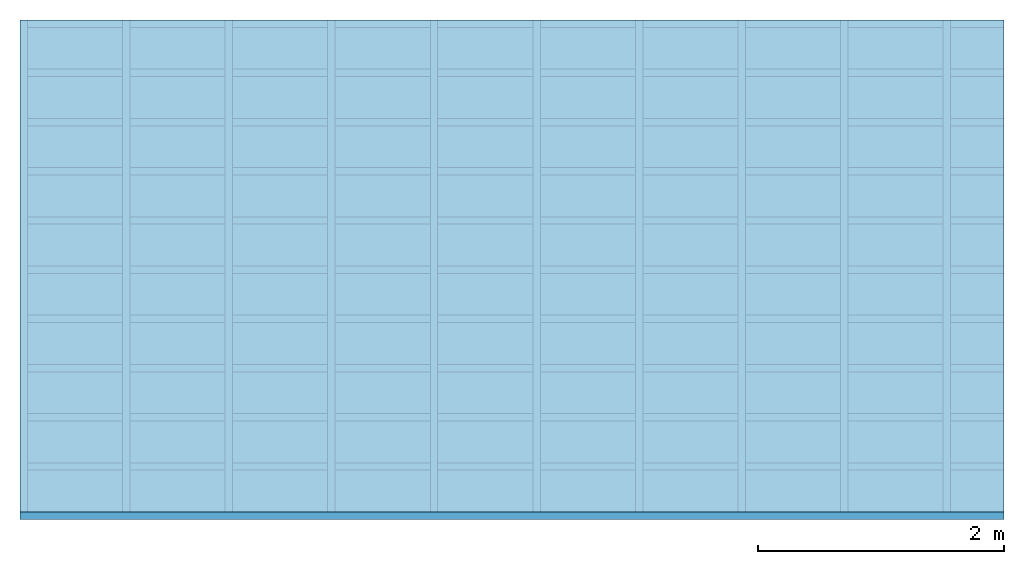
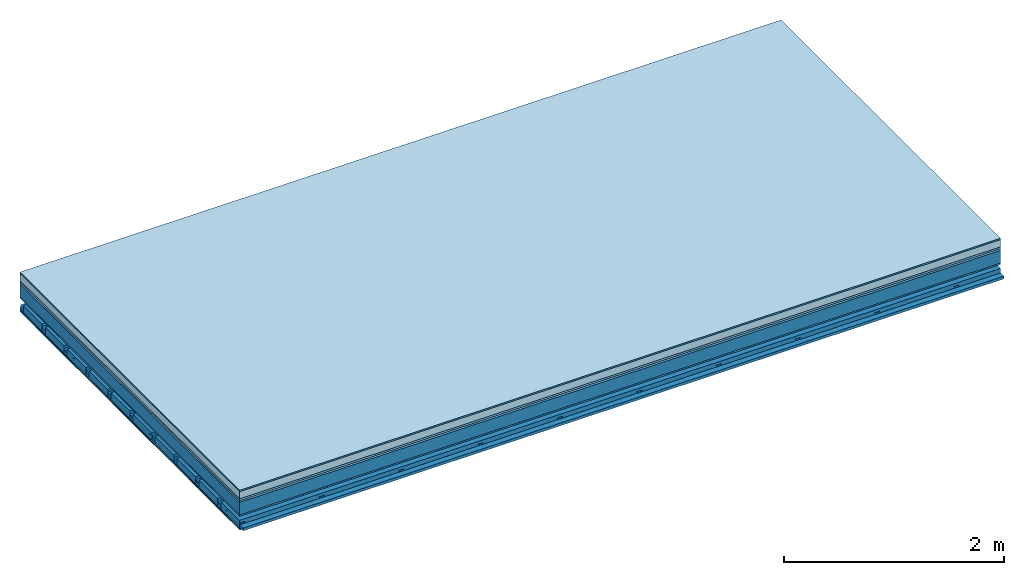
# One storey: 8 plates, 4 members, 1 element without a shape of its own.
"""IFC4 building model written with IfcOpenShell, lengths in metres."""

from ifc_helpers import new_model, si_unit, derived_unit, direction, frame, frame_2d, origin, origin_with_axes, place, context, project, spatial, polyline, rectangle, outline, extrude, material, layer, layer_set, type_object, element, aggregate, save


model = new_model("IFC4")

# Units and contexts
plan_context = context("Plan", 3, precision=1e-05, world=origin(), true_north=direction((0.0, 1.0)))
model_context = context("Model", 3, precision=1e-05, world=origin(), true_north=direction((0.0, 1.0)))
ifc_project = project(units=[si_unit("LENGTHUNIT", "METRE"), derived_unit("SOUNDPRESSUREUNIT", [(si_unit("PRESSUREUNIT", "PASCAL", prefix="MICRO"), 0)]), si_unit("ENERGYUNIT", "JOULE", prefix="MEGA"), si_unit("MASSUNIT", "GRAM", prefix="KILO"), derived_unit("THERMALTRANSMITTANCEUNIT", [(si_unit("POWERUNIT", "WATT"), 1), (si_unit("AREAUNIT", "SQUARE_METRE"), -1), (si_unit("THERMODYNAMICTEMPERATUREUNIT", "KELVIN"), -1)]), derived_unit("AREADENSITYUNIT", [(si_unit("MASSUNIT", "GRAM", prefix="KILO"), 1), (si_unit("AREAUNIT", "SQUARE_METRE"), -1)]), derived_unit("USERDEFINED", [(si_unit("ENERGYUNIT", "JOULE", prefix="MEGA"), 1), (si_unit("AREAUNIT", "SQUARE_METRE"), -1)])], contexts=[plan_context, model_context])

# Site, building, storey
site = spatial("IfcSite", under=ifc_project)
building_placement = place(None, origin())
building = spatial("IfcBuilding", under=site, at=building_placement)
storey_placement = place(building_placement, origin())
storey = spatial("IfcBuildingStorey", under=building, at=storey_placement)

# Slab, members, plates
ifc_material_1 = material(Category="11.013")
ifc_layer_1 = layer(ifc_material_1, 0.015, Name="Flooring")
ifc_material_2 = material(Name="Cement screed", Category="04.006")
ifc_layer_2 = layer(ifc_material_2, 0.08, Name="On-material")
ifc_material_3 = material(Name="Wood fiber generic product", Category="10.009")
ifc_layer_3 = layer(ifc_material_3, 0.02, Name="Impact sound insulation")
ifc_material_4 = material(Category="10.004")
ifc_layer_4 = layer(ifc_material_4, 0.02, Name="Additional insulation")
ifc_material_5 = material(Name="no composite action")
ifc_layer_5 = layer(ifc_material_5, 0.0, Name="Bond")
ifc_layer_6 = layer(None, 0.14, Name="Supporting structure")
ifc_material_6 = material(Name="of the art")
ifc_layer_7 = layer(ifc_material_6, 0.0, Name="Bond")
ifc_material_7 = material(Category="03.007")
ifc_layer_8 = layer(ifc_material_7, 0.015, Name="Lower layer 1")
ifc_layer_9 = layer(None, 0.095, Name="Coupling")
ifc_layer_10 = layer(None, 0.03, Name="Battens / profiles")
ifc_material_8 = material(Name="Plasterboard type A", Category="03.008")
ifc_layer_11 = layer(ifc_material_8, 0.0125, Name="Ceiling covering 1st layer")
ifc_layer_12 = layer(ifc_material_8, 0.0125, Name="Ceiling covering layer 2")
ifc_material_9 = material(Category="04.001")
ifc_layer_13 = layer(ifc_material_9, 0.003, Name="Surface / treatment")
ifc_layer_set = layer_set([ifc_layer_1, ifc_layer_2, ifc_layer_3, ifc_layer_4, ifc_layer_5, ifc_layer_6, ifc_layer_7, ifc_layer_8, ifc_layer_9, ifc_layer_10, ifc_layer_11, ifc_layer_12, ifc_layer_13])
slab_type = type_object("IfcSlabType", Name="A2160", PredefinedType="NOTDEFINED", material=ifc_layer_set)
slab_placement = place(None, frame((0.0, 0.0, 0.0), z_axis=(0.0, 0.0, -1.0), x_axis=(1.0, 0.0, 0.0)))
slab = element("IfcSlab", 1, at=slab_placement, inside=storey, type_object=slab_type, material=ifc_layer_set, Name="Slab #1")
ifc_material_10 = material(Name="Solid timber panel")
member_1_placement = place(slab_placement, origin())
member_1 = element("IfcMember", 2, at=member_1_placement, material=ifc_material_10, Name="Supporting structure", context=plan_context, shape_type="SweptSolid", body=[
    extrude(rectangle(XDim=1.0, YDim=0.14, at=frame_2d((0.5, 0.07), x_axis=(1.0, 0.0))), frame((0.0, 4.0, 0.135), z_axis=(0.0, -1.0, 0.0), x_axis=(1.0, 0.0, 0.0)), (0.0, 0.0, 1.0), 4.0),
    extrude(rectangle(XDim=1.0, YDim=0.14, at=frame_2d((0.5, 0.07), x_axis=(1.0, 0.0))), frame((1.0, 4.0, 0.135), z_axis=(0.0, -1.0, 0.0), x_axis=(1.0, 0.0, 0.0)), (0.0, 0.0, 1.0), 4.0),
    extrude(rectangle(XDim=1.0, YDim=0.14, at=frame_2d((0.5, 0.07), x_axis=(1.0, 0.0))), frame((2.0, 4.0, 0.135), z_axis=(0.0, -1.0, 0.0), x_axis=(1.0, 0.0, 0.0)), (0.0, 0.0, 1.0), 4.0),
    extrude(rectangle(XDim=1.0, YDim=0.14, at=frame_2d((0.5, 0.07), x_axis=(1.0, 0.0))), frame((3.0, 4.0, 0.135), z_axis=(0.0, -1.0, 0.0), x_axis=(1.0, 0.0, 0.0)), (0.0, 0.0, 1.0), 4.0),
    extrude(rectangle(XDim=1.0, YDim=0.14, at=frame_2d((0.5, 0.07), x_axis=(1.0, 0.0))), frame((4.0, 4.0, 0.135), z_axis=(0.0, -1.0, 0.0), x_axis=(1.0, 0.0, 0.0)), (0.0, 0.0, 1.0), 4.0),
    extrude(rectangle(XDim=1.0, YDim=0.14, at=frame_2d((0.5, 0.07), x_axis=(1.0, 0.0))), frame((5.0, 4.0, 0.135), z_axis=(0.0, -1.0, 0.0), x_axis=(1.0, 0.0, 0.0)), (0.0, 0.0, 1.0), 4.0),
    extrude(rectangle(XDim=1.0, YDim=0.14, at=frame_2d((0.5, 0.07), x_axis=(1.0, 0.0))), frame((6.0, 4.0, 0.135), z_axis=(0.0, -1.0, 0.0), x_axis=(1.0, 0.0, 0.0)), (0.0, 0.0, 1.0), 4.0),
    extrude(rectangle(XDim=1.0, YDim=0.14, at=frame_2d((0.5, 0.07), x_axis=(1.0, 0.0))), frame((7.0, 4.0, 0.135), z_axis=(0.0, -1.0, 0.0), x_axis=(1.0, 0.0, 0.0)), (0.0, 0.0, 1.0), 4.0),
])
ifc_material_11 = material()
member_2_placement = place(slab_placement, origin())
member_2 = element("IfcMember", 3, at=member_2_placement, material=ifc_material_11, Name="Coupling", context=plan_context, shape_type="SweptSolid", body=[
    extrude(outline(polyline([(0.0, 0.0), (0.06, 0.0), (0.04, 0.02), (0.02, 0.02), (0.0, 0.0)])), frame((0.0, 4.0, 0.365), z_axis=(0.0, -1.0, 0.0), x_axis=(1.0, 0.0, 0.0)), (0.0, 0.0, 1.0), 4.0),
    extrude(outline(polyline([(0.0, 0.0), (0.06, 0.0), (0.04, 0.02), (0.02, 0.02), (0.0, 0.0)])), frame((0.834, 4.0, 0.365), z_axis=(0.0, -1.0, 0.0), x_axis=(1.0, 0.0, 0.0)), (0.0, 0.0, 1.0), 4.0),
    extrude(outline(polyline([(0.0, 0.0), (0.06, 0.0), (0.04, 0.02), (0.02, 0.02), (0.0, 0.0)])), frame((1.668, 4.0, 0.365), z_axis=(0.0, -1.0, 0.0), x_axis=(1.0, 0.0, 0.0)), (0.0, 0.0, 1.0), 4.0),
    extrude(outline(polyline([(0.0, 0.0), (0.06, 0.0), (0.04, 0.02), (0.02, 0.02), (0.0, 0.0)])), frame((2.502, 4.0, 0.365), z_axis=(0.0, -1.0, 0.0), x_axis=(1.0, 0.0, 0.0)), (0.0, 0.0, 1.0), 4.0),
    extrude(outline(polyline([(0.0, 0.0), (0.06, 0.0), (0.04, 0.02), (0.02, 0.02), (0.0, 0.0)])), frame((3.336, 4.0, 0.365), z_axis=(0.0, -1.0, 0.0), x_axis=(1.0, 0.0, 0.0)), (0.0, 0.0, 1.0), 4.0),
    extrude(outline(polyline([(0.0, 0.0), (0.06, 0.0), (0.04, 0.02), (0.02, 0.02), (0.0, 0.0)])), frame((4.17, 4.0, 0.365), z_axis=(0.0, -1.0, 0.0), x_axis=(1.0, 0.0, 0.0)), (0.0, 0.0, 1.0), 4.0),
    extrude(outline(polyline([(0.0, 0.0), (0.06, 0.0), (0.04, 0.02), (0.02, 0.02), (0.0, 0.0)])), frame((5.004, 4.0, 0.365), z_axis=(0.0, -1.0, 0.0), x_axis=(1.0, 0.0, 0.0)), (0.0, 0.0, 1.0), 4.0),
    extrude(outline(polyline([(0.0, 0.0), (0.06, 0.0), (0.04, 0.02), (0.02, 0.02), (0.0, 0.0)])), frame((5.838, 4.0, 0.365), z_axis=(0.0, -1.0, 0.0), x_axis=(1.0, 0.0, 0.0)), (0.0, 0.0, 1.0), 4.0),
    extrude(outline(polyline([(0.0, 0.0), (0.06, 0.0), (0.04, 0.02), (0.02, 0.02), (0.0, 0.0)])), frame((6.672, 4.0, 0.365), z_axis=(0.0, -1.0, 0.0), x_axis=(1.0, 0.0, 0.0)), (0.0, 0.0, 1.0), 4.0),
    extrude(outline(polyline([(0.0, 0.0), (0.06, 0.0), (0.04, 0.02), (0.02, 0.02), (0.0, 0.0)])), frame((7.506, 4.0, 0.365), z_axis=(0.0, -1.0, 0.0), x_axis=(1.0, 0.0, 0.0)), (0.0, 0.0, 1.0), 4.0),
])
member_3_placement = place(slab_placement, origin())
member_3 = element("IfcMember", 4, at=member_3_placement, material=ifc_material_11, Name="Battens / profiles", context=plan_context, shape_type="SweptSolid", body=[
    extrude(rectangle(XDim=0.06, YDim=0.03, at=frame_2d((0.03, 0.015), x_axis=(1.0, 0.0))), frame((0.0, 0.0, 0.385), z_axis=(1.0, 0.0, 0.0), x_axis=(0.0, 1.0, 0.0)), (0.0, 0.0, 1.0), 8.0),
    extrude(rectangle(XDim=0.06, YDim=0.03, at=frame_2d((0.03, 0.015), x_axis=(1.0, 0.0))), frame((0.0, 0.4, 0.385), z_axis=(1.0, 0.0, 0.0), x_axis=(0.0, 1.0, 0.0)), (0.0, 0.0, 1.0), 8.0),
    extrude(rectangle(XDim=0.06, YDim=0.03, at=frame_2d((0.03, 0.015), x_axis=(1.0, 0.0))), frame((0.0, 0.8, 0.385), z_axis=(1.0, 0.0, 0.0), x_axis=(0.0, 1.0, 0.0)), (0.0, 0.0, 1.0), 8.0),
    extrude(rectangle(XDim=0.06, YDim=0.03, at=frame_2d((0.03, 0.015), x_axis=(1.0, 0.0))), frame((0.0, 1.2, 0.385), z_axis=(1.0, 0.0, 0.0), x_axis=(0.0, 1.0, 0.0)), (0.0, 0.0, 1.0), 8.0),
    extrude(rectangle(XDim=0.06, YDim=0.03, at=frame_2d((0.03, 0.015), x_axis=(1.0, 0.0))), frame((0.0, 1.6, 0.385), z_axis=(1.0, 0.0, 0.0), x_axis=(0.0, 1.0, 0.0)), (0.0, 0.0, 1.0), 8.0),
    extrude(rectangle(XDim=0.06, YDim=0.03, at=frame_2d((0.03, 0.015), x_axis=(1.0, 0.0))), frame((0.0, 2.0, 0.385), z_axis=(1.0, 0.0, 0.0), x_axis=(0.0, 1.0, 0.0)), (0.0, 0.0, 1.0), 8.0),
    extrude(rectangle(XDim=0.06, YDim=0.03, at=frame_2d((0.03, 0.015), x_axis=(1.0, 0.0))), frame((0.0, 2.4, 0.385), z_axis=(1.0, 0.0, 0.0), x_axis=(0.0, 1.0, 0.0)), (0.0, 0.0, 1.0), 8.0),
    extrude(rectangle(XDim=0.06, YDim=0.03, at=frame_2d((0.03, 0.015), x_axis=(1.0, 0.0))), frame((0.0, 2.8, 0.385), z_axis=(1.0, 0.0, 0.0), x_axis=(0.0, 1.0, 0.0)), (0.0, 0.0, 1.0), 8.0),
    extrude(rectangle(XDim=0.06, YDim=0.03, at=frame_2d((0.03, 0.015), x_axis=(1.0, 0.0))), frame((0.0, 3.2, 0.385), z_axis=(1.0, 0.0, 0.0), x_axis=(0.0, 1.0, 0.0)), (0.0, 0.0, 1.0), 8.0),
    extrude(rectangle(XDim=0.06, YDim=0.03, at=frame_2d((0.03, 0.015), x_axis=(1.0, 0.0))), frame((0.0, 3.6, 0.385), z_axis=(1.0, 0.0, 0.0), x_axis=(0.0, 1.0, 0.0)), (0.0, 0.0, 1.0), 8.0),
    extrude(rectangle(XDim=0.06, YDim=0.03, at=frame_2d((0.03, 0.015), x_axis=(1.0, 0.0))), frame((0.0, 4.0, 0.385), z_axis=(1.0, 0.0, 0.0), x_axis=(0.0, 1.0, 0.0)), (0.0, 0.0, 1.0), 8.0),
])
ifc_material_12 = material()
member_4_placement = place(slab_placement, origin())
member_4 = element("IfcMember", 5, at=member_4_placement, material=ifc_material_12, Name="Cavity", context=plan_context, shape_type="SweptSolid", body=[
    extrude(rectangle(XDim=0.34, YDim=0.08, at=frame_2d((0.17, 0.04), x_axis=(1.0, 0.0))), frame((0.0, 0.06, 0.335), z_axis=(1.0, 0.0, 0.0), x_axis=(0.0, 1.0, 0.0)), (0.0, 0.0, 1.0), 8.0),
    extrude(rectangle(XDim=0.34, YDim=0.08, at=frame_2d((0.17, 0.04), x_axis=(1.0, 0.0))), frame((0.0, 0.46, 0.335), z_axis=(1.0, 0.0, 0.0), x_axis=(0.0, 1.0, 0.0)), (0.0, 0.0, 1.0), 8.0),
    extrude(rectangle(XDim=0.34, YDim=0.08, at=frame_2d((0.17, 0.04), x_axis=(1.0, 0.0))), frame((0.0, 0.86, 0.335), z_axis=(1.0, 0.0, 0.0), x_axis=(0.0, 1.0, 0.0)), (0.0, 0.0, 1.0), 8.0),
    extrude(rectangle(XDim=0.34, YDim=0.08, at=frame_2d((0.17, 0.04), x_axis=(1.0, 0.0))), frame((0.0, 1.26, 0.335), z_axis=(1.0, 0.0, 0.0), x_axis=(0.0, 1.0, 0.0)), (0.0, 0.0, 1.0), 8.0),
    extrude(rectangle(XDim=0.34, YDim=0.08, at=frame_2d((0.17, 0.04), x_axis=(1.0, 0.0))), frame((0.0, 1.66, 0.335), z_axis=(1.0, 0.0, 0.0), x_axis=(0.0, 1.0, 0.0)), (0.0, 0.0, 1.0), 8.0),
    extrude(rectangle(XDim=0.34, YDim=0.08, at=frame_2d((0.17, 0.04), x_axis=(1.0, 0.0))), frame((0.0, 2.06, 0.335), z_axis=(1.0, 0.0, 0.0), x_axis=(0.0, 1.0, 0.0)), (0.0, 0.0, 1.0), 8.0),
    extrude(rectangle(XDim=0.34, YDim=0.08, at=frame_2d((0.17, 0.04), x_axis=(1.0, 0.0))), frame((0.0, 2.46, 0.335), z_axis=(1.0, 0.0, 0.0), x_axis=(0.0, 1.0, 0.0)), (0.0, 0.0, 1.0), 8.0),
    extrude(rectangle(XDim=0.34, YDim=0.08, at=frame_2d((0.17, 0.04), x_axis=(1.0, 0.0))), frame((0.0, 2.86, 0.335), z_axis=(1.0, 0.0, 0.0), x_axis=(0.0, 1.0, 0.0)), (0.0, 0.0, 1.0), 8.0),
    extrude(rectangle(XDim=0.34, YDim=0.08, at=frame_2d((0.17, 0.04), x_axis=(1.0, 0.0))), frame((0.0, 3.26, 0.335), z_axis=(1.0, 0.0, 0.0), x_axis=(0.0, 1.0, 0.0)), (0.0, 0.0, 1.0), 8.0),
    extrude(rectangle(XDim=0.34, YDim=0.08, at=frame_2d((0.17, 0.04), x_axis=(1.0, 0.0))), frame((0.0, 3.66, 0.335), z_axis=(1.0, 0.0, 0.0), x_axis=(0.0, 1.0, 0.0)), (0.0, 0.0, 1.0), 8.0),
])
plate_1_placement = place(slab_placement, origin())
plate_1 = element("IfcPlate", 6, at=plate_1_placement, material=ifc_material_1, Name="Flooring", context=plan_context, shape_type="SweptSolid", body=[
    extrude(rectangle(XDim=8.0, YDim=4.0, at=frame_2d((4.0, 2.0), x_axis=(1.0, 0.0))), origin_with_axes(), (0.0, 0.0, 1.0), 0.015),
])
plate_2_placement = place(slab_placement, origin())
plate_2 = element("IfcPlate", 7, at=plate_2_placement, material=ifc_material_2, Name="On-material", context=plan_context, shape_type="SweptSolid", body=[
    extrude(rectangle(XDim=8.0, YDim=4.0, at=frame_2d((4.0, 2.0), x_axis=(1.0, 0.0))), frame((0.0, 0.0, 0.015), z_axis=(0.0, 0.0, 1.0), x_axis=(1.0, 0.0, 0.0)), (0.0, 0.0, 1.0), 0.08),
])
plate_3_placement = place(slab_placement, origin())
plate_3 = element("IfcPlate", 8, at=plate_3_placement, material=ifc_material_3, Name="Impact sound insulation", context=plan_context, shape_type="SweptSolid", body=[
    extrude(rectangle(XDim=8.0, YDim=4.0, at=frame_2d((4.0, 2.0), x_axis=(1.0, 0.0))), frame((0.0, 0.0, 0.095), z_axis=(0.0, 0.0, 1.0), x_axis=(1.0, 0.0, 0.0)), (0.0, 0.0, 1.0), 0.02),
])
plate_4_placement = place(slab_placement, origin())
plate_4 = element("IfcPlate", 9, at=plate_4_placement, material=ifc_material_4, Name="Additional insulation", context=plan_context, shape_type="SweptSolid", body=[
    extrude(rectangle(XDim=8.0, YDim=4.0, at=frame_2d((4.0, 2.0), x_axis=(1.0, 0.0))), frame((0.0, 0.0, 0.115), z_axis=(0.0, 0.0, 1.0), x_axis=(1.0, 0.0, 0.0)), (0.0, 0.0, 1.0), 0.02),
])
plate_5_placement = place(slab_placement, origin())
plate_5 = element("IfcPlate", 10, at=plate_5_placement, material=ifc_material_7, Name="Lower layer 1", context=plan_context, shape_type="SweptSolid", body=[
    extrude(rectangle(XDim=8.0, YDim=4.0, at=frame_2d((4.0, 2.0), x_axis=(1.0, 0.0))), frame((0.0, 0.0, 0.275), z_axis=(0.0, 0.0, 1.0), x_axis=(1.0, 0.0, 0.0)), (0.0, 0.0, 1.0), 0.015),
])
plate_6_placement = place(slab_placement, origin())
plate_6 = element("IfcPlate", 11, at=plate_6_placement, material=ifc_material_8, Name="Ceiling covering 1st layer", context=plan_context, shape_type="SweptSolid", body=[
    extrude(rectangle(XDim=8.0, YDim=4.0, at=frame_2d((4.0, 2.0), x_axis=(1.0, 0.0))), frame((0.0, 0.0, 0.415), z_axis=(0.0, 0.0, 1.0), x_axis=(1.0, 0.0, 0.0)), (0.0, 0.0, 1.0), 0.0125),
])
plate_7_placement = place(slab_placement, origin())
plate_7 = element("IfcPlate", 12, at=plate_7_placement, material=ifc_material_8, Name="Ceiling covering layer 2", context=plan_context, shape_type="SweptSolid", body=[
    extrude(rectangle(XDim=8.0, YDim=4.0, at=frame_2d((4.0, 2.0), x_axis=(1.0, 0.0))), frame((0.0, 0.0, 0.4275), z_axis=(0.0, 0.0, 1.0), x_axis=(1.0, 0.0, 0.0)), (0.0, 0.0, 1.0), 0.0125),
])
plate_8_placement = place(slab_placement, origin())
plate_8 = element("IfcPlate", 13, at=plate_8_placement, material=ifc_material_9, Name="Surface / treatment", context=plan_context, shape_type="SweptSolid", body=[
    extrude(rectangle(XDim=8.0, YDim=4.0, at=frame_2d((4.0, 2.0), x_axis=(1.0, 0.0))), frame((0.0, 0.0, 0.44), z_axis=(0.0, 0.0, 1.0), x_axis=(1.0, 0.0, 0.0)), (0.0, 0.0, 1.0), 0.003),
])
aggregate(slab, [plate_1, plate_2, plate_3, plate_4, member_1, plate_5, member_2, member_3, member_4, plate_6, plate_7, plate_8])

save(model, "model.ifc")
